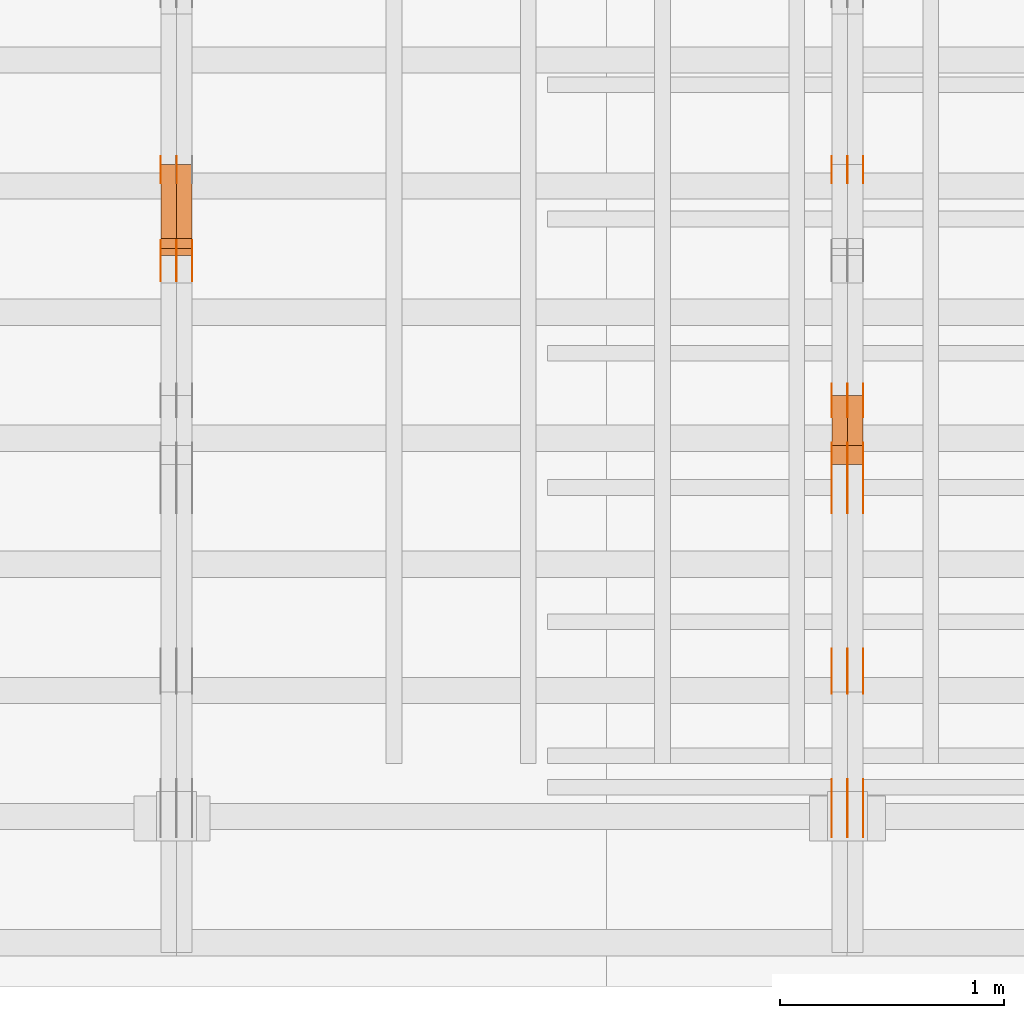
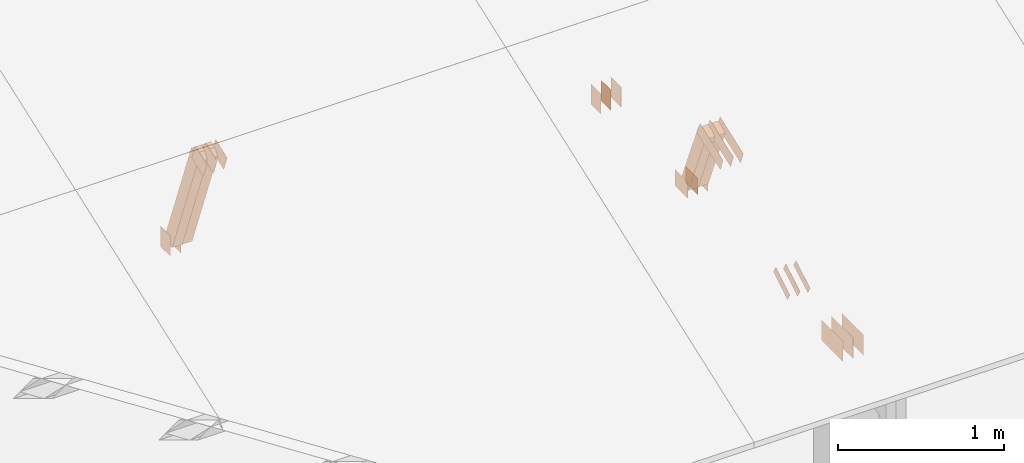
# One storey, part 141 of 189: 30 proxies.
"""IFC2X3 building model written with IfcOpenShell, lengths in millimetres."""

from ifc_helpers import new_model, entity, si_unit, converted_unit, derived_unit, direction, frame, frame_2d, origin, origin_2d_with_axis, place, context, subcontext, project, spatial, polyline, rectangle, outline, extrude, source, transform, mapped, material, type_object, type_shapes, element, save


model = new_model("IFC2X3")

# Units and contexts
model_context = context("Model", 3, precision=0.01, world=origin(), true_north=direction((6.12303176911189e-17, 1.0)))
body_context = subcontext(model_context, "Body", "Model", "MODEL_VIEW")
ifc_project = project(units=[si_unit("LENGTHUNIT", "METRE", prefix="MILLI"), si_unit("AREAUNIT", "SQUARE_METRE"), si_unit("VOLUMEUNIT", "CUBIC_METRE"), converted_unit("PLANEANGLEUNIT", "DEGREE", entity("IfcRatioMeasure", 0.0174532925199433), si_unit("PLANEANGLEUNIT", "RADIAN"), dimensions=[0, 0, 0, 0, 0, 0, 0]), si_unit("MASSUNIT", "GRAM", prefix="KILO"), derived_unit("MASSDENSITYUNIT", [(si_unit("MASSUNIT", "GRAM", prefix="KILO"), 1), (si_unit("LENGTHUNIT", "METRE"), -3)]), si_unit("TIMEUNIT", "SECOND"), si_unit("FREQUENCYUNIT", "HERTZ"), si_unit("THERMODYNAMICTEMPERATUREUNIT", "DEGREE_CELSIUS"), derived_unit("THERMALTRANSMITTANCEUNIT", [(si_unit("MASSUNIT", "GRAM", prefix="KILO"), 1), (si_unit("THERMODYNAMICTEMPERATUREUNIT", "KELVIN"), -1), (si_unit("TIMEUNIT", "SECOND"), -3)]), derived_unit("VOLUMETRICFLOWRATEUNIT", [(si_unit("LENGTHUNIT", "METRE"), 3), (si_unit("TIMEUNIT", "SECOND"), -1)]), si_unit("ELECTRICCURRENTUNIT", "AMPERE"), si_unit("ELECTRICVOLTAGEUNIT", "VOLT"), si_unit("POWERUNIT", "WATT"), si_unit("FORCEUNIT", "NEWTON"), si_unit("ILLUMINANCEUNIT", "LUX"), si_unit("LUMINOUSFLUXUNIT", "LUMEN"), si_unit("LUMINOUSINTENSITYUNIT", "CANDELA"), derived_unit("USERDEFINED", [(si_unit("MASSUNIT", "GRAM", prefix="KILO"), -1), (si_unit("LENGTHUNIT", "METRE"), -2), (si_unit("TIMEUNIT", "SECOND"), 3), (si_unit("LUMINOUSFLUXUNIT", "LUMEN"), 1)]), derived_unit("LINEARVELOCITYUNIT", [(si_unit("LENGTHUNIT", "METRE"), 1), (si_unit("TIMEUNIT", "SECOND"), -1)]), si_unit("PRESSUREUNIT", "PASCAL"), derived_unit("USERDEFINED", [(si_unit("LENGTHUNIT", "METRE"), -2), (si_unit("MASSUNIT", "GRAM", prefix="KILO"), 1), (si_unit("TIMEUNIT", "SECOND"), -2)])], contexts=[model_context])

# Site, building, storey
site_placement = place(None, origin())
site = spatial("IfcSite", under=ifc_project, at=site_placement, CompositionType="ELEMENT")
building_placement = place(site_placement, origin())
building = spatial("IfcBuilding", under=site, at=building_placement, CompositionType="ELEMENT")
storey_placement = place(building_placement, origin())
storey = spatial("IfcBuildingStorey", under=building, at=storey_placement, Name="Default", CompositionType="ELEMENT", Elevation=0.0)

# Proxies
ifc_material_1 = material(Name="IfcSurfaceStyle #247220")
building_element_proxy_type_1 = type_object("IfcBuildingElementProxyType", PredefinedType="NOTDEFINED", material=ifc_material_1)
shared_shape_1 = source(origin(), body_context, "Body", "SweptSolid", [
    extrude(rectangle(XDim=150.0, YDim=120.0, at=frame_2d((1.4210854715202e-14, -7.105427357601e-15), x_axis=(1.0, 0.0))), frame((75.0, 60.0004961323721, 0.0), z_axis=(0.0, 0.0, 1.0), x_axis=(-1.0, 0.0, 0.0)), (0.0, 0.0, 1.0), 1.3),
])
type_shapes(building_element_proxy_type_1, [shared_shape_1])
proxy_1_placement = place(building_placement, frame((45301.3, 2940.99169136763, 170.0), z_axis=(-1.0, 0.0, 0.0), x_axis=(0.0, 0.0, 1.0)))
element("IfcBuildingElementProxy", 1, at=proxy_1_placement, inside=storey, type_object=building_element_proxy_type_1, material=ifc_material_1, context=body_context, shape_type="MappedRepresentation", body=[
    mapped(shared_shape_1, transform((0.0, 0.0, 0.0), scale=1.0)),
])
ifc_material_2 = material(Name="IfcSurfaceStyle #247163")
building_element_proxy_type_2 = type_object("IfcBuildingElementProxyType", PredefinedType="NOTDEFINED", material=ifc_material_2)
shared_shape_2 = source(origin(), body_context, "Body", "SweptSolid", [
    extrude(rectangle(XDim=150.0, YDim=120.0, at=frame_2d((1.4210854715202e-14, -7.105427357601e-15), x_axis=(1.0, 0.0))), frame((75.0, 60.0004961323721, 0.0), z_axis=(0.0, 0.0, 1.0), x_axis=(-1.0, 0.0, 0.0)), (0.0, 0.0, 1.0), 1.29999999999999),
])
type_shapes(building_element_proxy_type_2, [shared_shape_2])
proxy_2_placement = place(building_placement, frame((45230.0, 2940.99169136763, 170.0), z_axis=(-1.0, 0.0, 0.0), x_axis=(0.0, 0.0, 1.0)))
element("IfcBuildingElementProxy", 2, at=proxy_2_placement, inside=storey, type_object=building_element_proxy_type_2, material=ifc_material_2, context=body_context, shape_type="MappedRepresentation", body=[
    mapped(shared_shape_2, transform((0.0, 0.0, 0.0), scale=1.0)),
])
ifc_material_3 = material(Name="IfcSurfaceStyle #247106")
building_element_proxy_type_3 = type_object("IfcBuildingElementProxyType", PredefinedType="NOTDEFINED", material=ifc_material_3)
shared_shape_3 = source(origin(), body_context, "Body", "SweptSolid", [
    extrude(rectangle(XDim=150.0, YDim=120.0, at=frame_2d((1.4210854715202e-14, -7.105427357601e-15), x_axis=(1.0, 0.0))), frame((75.0, 60.0004961323721, 0.0), z_axis=(0.0, 0.0, 1.0), x_axis=(-1.0, 0.0, 0.0)), (0.0, 0.0, 1.0), 1.29999999999999),
])
type_shapes(building_element_proxy_type_3, [shared_shape_3])
proxy_3_placement = place(building_placement, frame((45231.3, 2940.99169136763, 170.0), z_axis=(-1.0, 0.0, 0.0), x_axis=(0.0, 0.0, 1.0)))
element("IfcBuildingElementProxy", 3, at=proxy_3_placement, inside=storey, type_object=building_element_proxy_type_3, material=ifc_material_3, context=body_context, shape_type="MappedRepresentation", body=[
    mapped(shared_shape_3, transform((0.0, 0.0, 0.0), scale=1.0)),
])
ifc_material_4 = material(Name="IfcSurfaceStyle #247049")
building_element_proxy_type_4 = type_object("IfcBuildingElementProxyType", PredefinedType="NOTDEFINED", material=ifc_material_4)
shared_shape_4 = source(origin(), body_context, "Body", "SweptSolid", [
    extrude(rectangle(XDim=150.0, YDim=120.0, at=frame_2d((1.4210854715202e-14, -7.105427357601e-15), x_axis=(1.0, 0.0))), frame((75.0, 60.0004961323721, 0.0), z_axis=(0.0, 0.0, 1.0), x_axis=(-1.0, 0.0, 0.0)), (0.0, 0.0, 1.0), 1.29999999999999),
])
type_shapes(building_element_proxy_type_4, [shared_shape_4])
proxy_4_placement = place(building_placement, frame((45160.0, 2940.99169136763, 170.0), z_axis=(-1.0, 0.0, 0.0), x_axis=(0.0, 0.0, 1.0)))
element("IfcBuildingElementProxy", 4, at=proxy_4_placement, inside=storey, type_object=building_element_proxy_type_4, material=ifc_material_4, context=body_context, shape_type="MappedRepresentation", body=[
    mapped(shared_shape_4, transform((0.0, 0.0, 0.0), scale=1.0)),
])
ifc_material_5 = material(Name="IfcSurfaceStyle #246308")
building_element_proxy_type_5 = type_object("IfcBuildingElementProxyType", PredefinedType="NOTDEFINED", material=ifc_material_5)
shared_shape_5 = source(origin(), body_context, "Body", "SweptSolid", [
    extrude(rectangle(XDim=150.0, YDim=120.0, at=origin_2d_with_axis()), frame((75.0004757715869, 60.0, 0.0), z_axis=(0.0, 0.0, 1.0), x_axis=(-1.0, 0.0, 0.0)), (0.0, 0.0, 1.0), 1.3),
])
type_shapes(building_element_proxy_type_5, [shared_shape_5])
proxy_5_placement = place(building_placement, frame((45301.3, 1892.68702422841, 305.0), z_axis=(-1.0, 0.0, 0.0), x_axis=(0.0, 1.0, 0.0)))
element("IfcBuildingElementProxy", 5, at=proxy_5_placement, inside=storey, type_object=building_element_proxy_type_5, material=ifc_material_5, context=body_context, shape_type="MappedRepresentation", body=[
    mapped(shared_shape_5, transform((0.0, 0.0, 0.0), scale=1.0)),
])
ifc_material_6 = material(Name="IfcSurfaceStyle #246251")
building_element_proxy_type_6 = type_object("IfcBuildingElementProxyType", PredefinedType="NOTDEFINED", material=ifc_material_6)
shared_shape_6 = source(origin(), body_context, "Body", "SweptSolid", [
    extrude(rectangle(XDim=150.0, YDim=120.0, at=origin_2d_with_axis()), frame((75.0004757715869, 60.0, 0.0), z_axis=(0.0, 0.0, 1.0), x_axis=(-1.0, 0.0, 0.0)), (0.0, 0.0, 1.0), 1.29999999999999),
])
type_shapes(building_element_proxy_type_6, [shared_shape_6])
proxy_6_placement = place(building_placement, frame((45230.0, 1892.68702422841, 305.0), z_axis=(-1.0, 0.0, 0.0), x_axis=(0.0, 1.0, 0.0)))
element("IfcBuildingElementProxy", 6, at=proxy_6_placement, inside=storey, type_object=building_element_proxy_type_6, material=ifc_material_6, context=body_context, shape_type="MappedRepresentation", body=[
    mapped(shared_shape_6, transform((0.0, 0.0, 0.0), scale=1.0)),
])
ifc_material_7 = material(Name="IfcSurfaceStyle #246194")
building_element_proxy_type_7 = type_object("IfcBuildingElementProxyType", PredefinedType="NOTDEFINED", material=ifc_material_7)
shared_shape_7 = source(origin(), body_context, "Body", "SweptSolid", [
    extrude(rectangle(XDim=150.0, YDim=120.0, at=origin_2d_with_axis()), frame((75.0004757715869, 60.0, 0.0), z_axis=(0.0, 0.0, 1.0), x_axis=(-1.0, 0.0, 0.0)), (0.0, 0.0, 1.0), 1.29999999999999),
])
type_shapes(building_element_proxy_type_7, [shared_shape_7])
proxy_7_placement = place(building_placement, frame((45231.3, 1892.68702422841, 305.0), z_axis=(-1.0, 0.0, 0.0), x_axis=(0.0, 1.0, 0.0)))
element("IfcBuildingElementProxy", 7, at=proxy_7_placement, inside=storey, type_object=building_element_proxy_type_7, material=ifc_material_7, context=body_context, shape_type="MappedRepresentation", body=[
    mapped(shared_shape_7, transform((0.0, 0.0, 0.0), scale=1.0)),
])
ifc_material_8 = material(Name="IfcSurfaceStyle #246137")
building_element_proxy_type_8 = type_object("IfcBuildingElementProxyType", PredefinedType="NOTDEFINED", material=ifc_material_8)
shared_shape_8 = source(origin(), body_context, "Body", "SweptSolid", [
    extrude(rectangle(XDim=150.0, YDim=120.0, at=origin_2d_with_axis()), frame((75.0004757715869, 60.0, 0.0), z_axis=(0.0, 0.0, 1.0), x_axis=(-1.0, 0.0, 0.0)), (0.0, 0.0, 1.0), 1.29999999999999),
])
type_shapes(building_element_proxy_type_8, [shared_shape_8])
proxy_8_placement = place(building_placement, frame((45160.0, 1892.68702422841, 305.0), z_axis=(-1.0, 0.0, 0.0), x_axis=(0.0, 1.0, 0.0)))
element("IfcBuildingElementProxy", 8, at=proxy_8_placement, inside=storey, type_object=building_element_proxy_type_8, material=ifc_material_8, context=body_context, shape_type="MappedRepresentation", body=[
    mapped(shared_shape_8, transform((0.0, 0.0, 0.0), scale=1.0)),
])
ifc_material_9 = material(Name="IfcSurfaceStyle #246080")
building_element_proxy_type_9 = type_object("IfcBuildingElementProxyType", PredefinedType="NOTDEFINED", material=ifc_material_9)
shared_shape_9 = source(origin(), body_context, "Body", "SweptSolid", [
    extrude(outline(polyline([(-150.000217420008, -47.9999344162752), (150.000165800718, -47.9999344162752), (150.000227857633, 47.9999344162752), (-150.000176238343, 47.9999344162752), (-150.000217420008, -47.9999344162752)])), frame((150.000227857633, 48.0000430742566, 0.0), z_axis=(0.0, 0.0, 1.0), x_axis=(-1.0, 0.0, 0.0)), (0.0, 0.0, 1.0), 1.29999999999999),
])
type_shapes(building_element_proxy_type_9, [shared_shape_9])
proxy_9_placement = place(building_placement, frame((45301.3, 1464.46484375, 723.378723144533), z_axis=(-1.0, 0.0, 0.0), x_axis=(0.0, 0.939692620785908, 0.342020143325669)))
element("IfcBuildingElementProxy", 9, at=proxy_9_placement, inside=storey, type_object=building_element_proxy_type_9, material=ifc_material_9, context=body_context, shape_type="MappedRepresentation", body=[
    mapped(shared_shape_9, transform((0.0, 0.0, 0.0), scale=1.0)),
])
ifc_material_10 = material(Name="IfcSurfaceStyle #246023")
building_element_proxy_type_10 = type_object("IfcBuildingElementProxyType", PredefinedType="NOTDEFINED", material=ifc_material_10)
shared_shape_10 = source(origin(), body_context, "Body", "SweptSolid", [
    extrude(outline(polyline([(-150.000217420008, -47.9999344162752), (150.000165800718, -47.9999344162752), (150.000227857633, 47.9999344162752), (-150.000176238343, 47.9999344162752), (-150.000217420008, -47.9999344162752)])), frame((150.000227857633, 48.0000430742566, 0.0), z_axis=(0.0, 0.0, 1.0), x_axis=(-1.0, 0.0, 0.0)), (0.0, 0.0, 1.0), 1.29999999999998),
])
type_shapes(building_element_proxy_type_10, [shared_shape_10])
proxy_10_placement = place(building_placement, frame((45230.0, 1464.46484375, 723.378723144533), z_axis=(-1.0, 0.0, 0.0), x_axis=(0.0, 0.939692620785908, 0.342020143325669)))
element("IfcBuildingElementProxy", 10, at=proxy_10_placement, inside=storey, type_object=building_element_proxy_type_10, material=ifc_material_10, context=body_context, shape_type="MappedRepresentation", body=[
    mapped(shared_shape_10, transform((0.0, 0.0, 0.0), scale=1.0)),
])
ifc_material_11 = material(Name="IfcSurfaceStyle #245966")
building_element_proxy_type_11 = type_object("IfcBuildingElementProxyType", PredefinedType="NOTDEFINED", material=ifc_material_11)
shared_shape_11 = source(origin(), body_context, "Body", "SweptSolid", [
    extrude(outline(polyline([(-150.000217420008, -47.9999344162752), (150.000165800718, -47.9999344162752), (150.000227857633, 47.9999344162752), (-150.000176238343, 47.9999344162752), (-150.000217420008, -47.9999344162752)])), frame((150.000227857633, 48.0000430742566, 0.0), z_axis=(0.0, 0.0, 1.0), x_axis=(-1.0, 0.0, 0.0)), (0.0, 0.0, 1.0), 1.29999999999998),
])
type_shapes(building_element_proxy_type_11, [shared_shape_11])
proxy_11_placement = place(building_placement, frame((45231.3, 1464.46484375, 723.378723144533), z_axis=(-1.0, 0.0, 0.0), x_axis=(0.0, 0.939692620785908, 0.342020143325669)))
element("IfcBuildingElementProxy", 11, at=proxy_11_placement, inside=storey, type_object=building_element_proxy_type_11, material=ifc_material_11, context=body_context, shape_type="MappedRepresentation", body=[
    mapped(shared_shape_11, transform((0.0, 0.0, 0.0), scale=1.0)),
])
ifc_material_12 = material(Name="IfcSurfaceStyle #245909")
building_element_proxy_type_12 = type_object("IfcBuildingElementProxyType", PredefinedType="NOTDEFINED", material=ifc_material_12)
shared_shape_12 = source(origin(), body_context, "Body", "SweptSolid", [
    extrude(outline(polyline([(-150.000217420008, -47.9999344162752), (150.000165800718, -47.9999344162752), (150.000227857633, 47.9999344162752), (-150.000176238343, 47.9999344162752), (-150.000217420008, -47.9999344162752)])), frame((150.000227857633, 48.0000430742566, 0.0), z_axis=(0.0, 0.0, 1.0), x_axis=(-1.0, 0.0, 0.0)), (0.0, 0.0, 1.0), 1.29999999999998),
])
type_shapes(building_element_proxy_type_12, [shared_shape_12])
proxy_12_placement = place(building_placement, frame((45160.0, 1464.46484375, 723.378723144533), z_axis=(-1.0, 0.0, 0.0), x_axis=(0.0, 0.939692620785908, 0.342020143325669)))
element("IfcBuildingElementProxy", 12, at=proxy_12_placement, inside=storey, type_object=building_element_proxy_type_12, material=ifc_material_12, context=body_context, shape_type="MappedRepresentation", body=[
    mapped(shared_shape_12, transform((0.0, 0.0, 0.0), scale=1.0)),
])
ifc_material_13 = material(Name="IfcSurfaceStyle #245396")
building_element_proxy_type_13 = type_object("IfcBuildingElementProxyType", PredefinedType="NOTDEFINED", material=ifc_material_13)
shared_shape_13 = source(origin(), body_context, "Body", "SweptSolid", [
    extrude(outline(polyline([(-100.000388510424, -29.9995882393532), (100.000691805256, -29.9995882393532), (100.000392424258, 29.9995882393532), (-100.00069571909, 29.9995882393532), (-100.000388510424, -29.9995882393532)])), frame((100.000691805256, 30.0002299338894, 0.0), z_axis=(0.0, 0.0, 1.0), x_axis=(-1.0, 0.0, 0.0)), (0.0, 0.0, 1.0), 1.3),
])
type_shapes(building_element_proxy_type_13, [shared_shape_13])
proxy_13_placement = place(building_placement, frame((45301.3, 656.945055513712, 219.45219322107), z_axis=(-1.0, 0.0, 0.0), x_axis=(0.0, 0.858392121304013, 0.51299411895576)))
element("IfcBuildingElementProxy", 13, at=proxy_13_placement, inside=storey, type_object=building_element_proxy_type_13, material=ifc_material_13, context=body_context, shape_type="MappedRepresentation", body=[
    mapped(shared_shape_13, transform((0.0, 0.0, 0.0), scale=1.0)),
])
ifc_material_14 = material(Name="IfcSurfaceStyle #245339")
building_element_proxy_type_14 = type_object("IfcBuildingElementProxyType", PredefinedType="NOTDEFINED", material=ifc_material_14)
shared_shape_14 = source(origin(), body_context, "Body", "SweptSolid", [
    extrude(outline(polyline([(-100.000388510424, -29.9995882393532), (100.000691805256, -29.9995882393532), (100.000392424258, 29.9995882393532), (-100.00069571909, 29.9995882393532), (-100.000388510424, -29.9995882393532)])), frame((100.000691805256, 30.0002299338894, 0.0), z_axis=(0.0, 0.0, 1.0), x_axis=(-1.0, 0.0, 0.0)), (0.0, 0.0, 1.0), 1.29999999999998),
])
type_shapes(building_element_proxy_type_14, [shared_shape_14])
proxy_14_placement = place(building_placement, frame((45230.0, 656.945055513712, 219.45219322107), z_axis=(-1.0, 0.0, 0.0), x_axis=(0.0, 0.858392121304013, 0.51299411895576)))
element("IfcBuildingElementProxy", 14, at=proxy_14_placement, inside=storey, type_object=building_element_proxy_type_14, material=ifc_material_14, context=body_context, shape_type="MappedRepresentation", body=[
    mapped(shared_shape_14, transform((0.0, 0.0, 0.0), scale=1.0)),
])
ifc_material_15 = material(Name="IfcSurfaceStyle #245282")
building_element_proxy_type_15 = type_object("IfcBuildingElementProxyType", PredefinedType="NOTDEFINED", material=ifc_material_15)
shared_shape_15 = source(origin(), body_context, "Body", "SweptSolid", [
    extrude(outline(polyline([(-100.000388510424, -29.9995882393532), (100.000691805256, -29.9995882393532), (100.000392424258, 29.9995882393532), (-100.00069571909, 29.9995882393532), (-100.000388510424, -29.9995882393532)])), frame((100.000691805256, 30.0002299338894, 0.0), z_axis=(0.0, 0.0, 1.0), x_axis=(-1.0, 0.0, 0.0)), (0.0, 0.0, 1.0), 1.29999999999998),
])
type_shapes(building_element_proxy_type_15, [shared_shape_15])
proxy_15_placement = place(building_placement, frame((45231.3, 656.945055513712, 219.45219322107), z_axis=(-1.0, 0.0, 0.0), x_axis=(0.0, 0.858392121304013, 0.51299411895576)))
element("IfcBuildingElementProxy", 15, at=proxy_15_placement, inside=storey, type_object=building_element_proxy_type_15, material=ifc_material_15, context=body_context, shape_type="MappedRepresentation", body=[
    mapped(shared_shape_15, transform((0.0, 0.0, 0.0), scale=1.0)),
])
ifc_material_16 = material(Name="IfcSurfaceStyle #245225")
building_element_proxy_type_16 = type_object("IfcBuildingElementProxyType", PredefinedType="NOTDEFINED", material=ifc_material_16)
shared_shape_16 = source(origin(), body_context, "Body", "SweptSolid", [
    extrude(outline(polyline([(-100.000388510424, -29.9995882393532), (100.000691805256, -29.9995882393532), (100.000392424258, 29.9995882393532), (-100.00069571909, 29.9995882393532), (-100.000388510424, -29.9995882393532)])), frame((100.000691805256, 30.0002299338894, 0.0), z_axis=(0.0, 0.0, 1.0), x_axis=(-1.0, 0.0, 0.0)), (0.0, 0.0, 1.0), 1.29999999999999),
])
type_shapes(building_element_proxy_type_16, [shared_shape_16])
proxy_16_placement = place(building_placement, frame((45160.0, 656.945055513712, 219.45219322107), z_axis=(-1.0, 0.0, 0.0), x_axis=(0.0, 0.858392121304013, 0.51299411895576)))
element("IfcBuildingElementProxy", 16, at=proxy_16_placement, inside=storey, type_object=building_element_proxy_type_16, material=ifc_material_16, context=body_context, shape_type="MappedRepresentation", body=[
    mapped(shared_shape_16, transform((0.0, 0.0, 0.0), scale=1.0)),
])
ifc_material_17 = material(Name="IfcSurfaceStyle #243860")
building_element_proxy_type_17 = type_object("IfcBuildingElementProxyType", PredefinedType="NOTDEFINED", material=ifc_material_17)
shared_shape_17 = source(origin(), body_context, "Body", "SweptSolid", [
    extrude(rectangle(XDim=258.0, YDim=151.999992370605, at=origin_2d_with_axis()), frame((129.0, 76.0000049445079, 0.0), z_axis=(0.0, 0.0, 1.0), x_axis=(-1.0, 0.0, 0.0)), (0.0, 0.0, 1.0), 0.999999999999984),
])
type_shapes(building_element_proxy_type_17, [shared_shape_17])
proxy_17_placement = place(building_placement, frame((45301.0, 16.236328125, 268.138222870533), z_axis=(-1.0, 0.0, 0.0), x_axis=(0.0, 1.0, 0.0)))
element("IfcBuildingElementProxy", 17, at=proxy_17_placement, inside=storey, type_object=building_element_proxy_type_17, material=ifc_material_17, Name="GNT100S 152x258", context=body_context, shape_type="MappedRepresentation", body=[
    mapped(shared_shape_17, transform((0.0, 0.0, 0.0), scale=1.0)),
])
ifc_material_18 = material(Name="IfcSurfaceStyle #243803")
building_element_proxy_type_18 = type_object("IfcBuildingElementProxyType", PredefinedType="NOTDEFINED", material=ifc_material_18)
shared_shape_18 = source(origin(), body_context, "Body", "SweptSolid", [
    extrude(rectangle(XDim=258.0, YDim=151.999992370605, at=origin_2d_with_axis()), frame((129.0, 76.0000049445079, 0.0), z_axis=(0.0, 0.0, 1.0), x_axis=(-1.0, 0.0, 0.0)), (0.0, 0.0, 1.0), 0.999999999999984),
])
type_shapes(building_element_proxy_type_18, [shared_shape_18])
proxy_18_placement = place(building_placement, frame((45230.0, 16.236328125, 268.138222870533), z_axis=(-1.0, 0.0, 0.0), x_axis=(0.0, 1.0, 0.0)))
element("IfcBuildingElementProxy", 18, at=proxy_18_placement, inside=storey, type_object=building_element_proxy_type_18, material=ifc_material_18, Name="GNT100S 152x258", context=body_context, shape_type="MappedRepresentation", body=[
    mapped(shared_shape_18, transform((0.0, 0.0, 0.0), scale=1.0)),
])
ifc_material_19 = material(Name="IfcSurfaceStyle #243746")
building_element_proxy_type_19 = type_object("IfcBuildingElementProxyType", PredefinedType="NOTDEFINED", material=ifc_material_19)
shared_shape_19 = source(origin(), body_context, "Body", "SweptSolid", [
    extrude(rectangle(XDim=258.0, YDim=151.999992370605, at=origin_2d_with_axis()), frame((129.0, 76.0000049445079, 0.0), z_axis=(0.0, 0.0, 1.0), x_axis=(-1.0, 0.0, 0.0)), (0.0, 0.0, 1.0), 0.999999999999984),
])
type_shapes(building_element_proxy_type_19, [shared_shape_19])
proxy_19_placement = place(building_placement, frame((45231.0, 16.236328125, 268.138222870533), z_axis=(-1.0, 0.0, 0.0), x_axis=(0.0, 1.0, 0.0)))
element("IfcBuildingElementProxy", 19, at=proxy_19_placement, inside=storey, type_object=building_element_proxy_type_19, material=ifc_material_19, Name="GNT100S 152x258", context=body_context, shape_type="MappedRepresentation", body=[
    mapped(shared_shape_19, transform((0.0, 0.0, 0.0), scale=1.0)),
])
ifc_material_20 = material(Name="IfcSurfaceStyle #243689")
building_element_proxy_type_20 = type_object("IfcBuildingElementProxyType", PredefinedType="NOTDEFINED", material=ifc_material_20)
shared_shape_20 = source(origin(), body_context, "Body", "SweptSolid", [
    extrude(rectangle(XDim=258.0, YDim=151.999992370605, at=origin_2d_with_axis()), frame((129.0, 76.0000049445079, 0.0), z_axis=(0.0, 0.0, 1.0), x_axis=(-1.0, 0.0, 0.0)), (0.0, 0.0, 1.0), 0.999999999999984),
])
type_shapes(building_element_proxy_type_20, [shared_shape_20])
proxy_20_placement = place(building_placement, frame((45160.0, 16.236328125, 268.138222870533), z_axis=(-1.0, 0.0, 0.0), x_axis=(0.0, 1.0, 0.0)))
element("IfcBuildingElementProxy", 20, at=proxy_20_placement, inside=storey, type_object=building_element_proxy_type_20, material=ifc_material_20, Name="GNT100S 152x258", context=body_context, shape_type="MappedRepresentation", body=[
    mapped(shared_shape_20, transform((0.0, 0.0, 0.0), scale=1.0)),
])
ifc_material_21 = material(Name="IfcSurfaceStyle #238892")
building_element_proxy_type_21 = type_object("IfcBuildingElementProxyType", Name="T1-W15 238890", PredefinedType="NOTDEFINED", material=ifc_material_21)
shared_shape_21 = source(origin(), body_context, "Body", "SweptSolid", [
    extrude(outline(polyline([(-317.132720418368, -47.5005147440206), (220.445242566881, -47.5005147440206), (227.5021778825, -0.000126286009697951), (225.500088907744, 47.5005778870255), (-356.314788938758, 47.5005778870255), (-317.132720418368, -47.5005147440206)])), frame((227.5021778825, 47.5005778870255, 0.0), z_axis=(0.0, 0.0, 1.0), x_axis=(-1.0, 0.0, 0.0)), (0.0, 0.0, 1.0), 70.0),
])
type_shapes(building_element_proxy_type_21, [shared_shape_21])
proxy_21_placement = place(building_placement, frame((45300.0, 1767.47882447529, 784.714556181707), z_axis=(-1.0, 0.0, 0.0), x_axis=(0.0, 0.381283266795389, -0.924458257825542)))
element("IfcBuildingElementProxy", 21, at=proxy_21_placement, inside=storey, type_object=building_element_proxy_type_21, material=ifc_material_21, Name="T1-W15", context=body_context, shape_type="MappedRepresentation", body=[
    mapped(shared_shape_21, transform((0.0, 0.0, 0.0), scale=1.0)),
])
ifc_material_22 = material(Name="IfcSurfaceStyle #238826")
building_element_proxy_type_22 = type_object("IfcBuildingElementProxyType", Name="T1-W15 238824", PredefinedType="NOTDEFINED", material=ifc_material_22)
shared_shape_22 = source(origin(), body_context, "Body", "SweptSolid", [
    extrude(outline(polyline([(-317.132720418368, -47.5005147440206), (220.445242566881, -47.5005147440206), (227.5021778825, -0.000126286009697951), (225.500088907744, 47.5005778870255), (-356.314788938758, 47.5005778870255), (-317.132720418368, -47.5005147440206)])), frame((227.5021778825, 47.5005778870255, 0.0), z_axis=(0.0, 0.0, 1.0), x_axis=(-1.0, 0.0, 0.0)), (0.0, 0.0, 1.0), 70.0),
])
type_shapes(building_element_proxy_type_22, [shared_shape_22])
proxy_22_placement = place(building_placement, frame((45230.0, 1767.47882447529, 784.714556181707), z_axis=(-1.0, 0.0, 0.0), x_axis=(0.0, 0.381283266795389, -0.924458257825542)))
element("IfcBuildingElementProxy", 22, at=proxy_22_placement, inside=storey, type_object=building_element_proxy_type_22, material=ifc_material_22, Name="T1-W15", context=body_context, shape_type="MappedRepresentation", body=[
    mapped(shared_shape_22, transform((0.0, 0.0, 0.0), scale=1.0)),
])
ifc_material_23 = material(Name="IfcSurfaceStyle #231316")
building_element_proxy_type_23 = type_object("IfcBuildingElementProxyType", PredefinedType="NOTDEFINED", material=ifc_material_23)
shared_shape_23 = source(origin(), body_context, "Body", "SweptSolid", [
    extrude(rectangle(XDim=150.0, YDim=120.0, at=frame_2d((1.4210854715202e-14, -7.105427357601e-15), x_axis=(1.0, 0.0))), frame((75.0, 60.0004961323721, 0.0), z_axis=(0.0, 0.0, 1.0), x_axis=(-1.0, 0.0, 0.0)), (0.0, 0.0, 1.0), 1.29999999999999),
])
type_shapes(building_element_proxy_type_23, [shared_shape_23])
proxy_23_placement = place(building_placement, frame((42231.3, 2940.99169136763, 170.0), z_axis=(-1.0, 0.0, 0.0), x_axis=(0.0, 0.0, 1.0)))
element("IfcBuildingElementProxy", 23, at=proxy_23_placement, inside=storey, type_object=building_element_proxy_type_23, material=ifc_material_23, context=body_context, shape_type="MappedRepresentation", body=[
    mapped(shared_shape_23, transform((0.0, 0.0, 0.0), scale=1.0)),
])
ifc_material_24 = material(Name="IfcSurfaceStyle #231259")
building_element_proxy_type_24 = type_object("IfcBuildingElementProxyType", PredefinedType="NOTDEFINED", material=ifc_material_24)
shared_shape_24 = source(origin(), body_context, "Body", "SweptSolid", [
    extrude(rectangle(XDim=150.0, YDim=120.0, at=frame_2d((1.4210854715202e-14, -7.105427357601e-15), x_axis=(1.0, 0.0))), frame((75.0, 60.0004961323721, 0.0), z_axis=(0.0, 0.0, 1.0), x_axis=(-1.0, 0.0, 0.0)), (0.0, 0.0, 1.0), 1.29999999999999),
])
type_shapes(building_element_proxy_type_24, [shared_shape_24])
proxy_24_placement = place(building_placement, frame((42160.0, 2940.99169136763, 170.0), z_axis=(-1.0, 0.0, 0.0), x_axis=(0.0, 0.0, 1.0)))
element("IfcBuildingElementProxy", 24, at=proxy_24_placement, inside=storey, type_object=building_element_proxy_type_24, material=ifc_material_24, context=body_context, shape_type="MappedRepresentation", body=[
    mapped(shared_shape_24, transform((0.0, 0.0, 0.0), scale=1.0)),
])
ifc_material_25 = material(Name="IfcSurfaceStyle #231202")
building_element_proxy_type_25 = type_object("IfcBuildingElementProxyType", PredefinedType="NOTDEFINED", material=ifc_material_25)
shared_shape_25 = source(origin(), body_context, "Body", "SweptSolid", [
    extrude(outline(polyline([(-75.0008071857483, -59.9999039432187), (75.0002916555677, -59.9999039432187), (75.0008280609982, 59.9999039432187), (-75.0003125308176, 59.9999039432187), (-75.0008071857483, -59.9999039432187)])), frame((75.0008280609982, 60.0002349219685, 0.0), z_axis=(0.0, 0.0, 1.0), x_axis=(-1.0, 0.0, 0.0)), (0.0, 0.0, 1.0), 1.3),
])
type_shapes(building_element_proxy_type_25, [shared_shape_25])
proxy_25_placement = place(building_placement, frame((42301.3, 2502.466796875, 1113.95080566406), z_axis=(-1.0, 0.0, 0.0), x_axis=(0.0, 0.939692620785908, 0.342020143325669)))
element("IfcBuildingElementProxy", 25, at=proxy_25_placement, inside=storey, type_object=building_element_proxy_type_25, material=ifc_material_25, context=body_context, shape_type="MappedRepresentation", body=[
    mapped(shared_shape_25, transform((0.0, 0.0, 0.0), scale=1.0)),
])
ifc_material_26 = material(Name="IfcSurfaceStyle #231145")
building_element_proxy_type_26 = type_object("IfcBuildingElementProxyType", PredefinedType="NOTDEFINED", material=ifc_material_26)
shared_shape_26 = source(origin(), body_context, "Body", "SweptSolid", [
    extrude(outline(polyline([(-75.0008071857483, -59.9999039432187), (75.0002916555677, -59.9999039432187), (75.0008280609982, 59.9999039432187), (-75.0003125308176, 59.9999039432187), (-75.0008071857483, -59.9999039432187)])), frame((75.0008280609982, 60.0002349219685, 0.0), z_axis=(0.0, 0.0, 1.0), x_axis=(-1.0, 0.0, 0.0)), (0.0, 0.0, 1.0), 1.29999999999999),
])
type_shapes(building_element_proxy_type_26, [shared_shape_26])
proxy_26_placement = place(building_placement, frame((42230.0, 2502.466796875, 1113.95080566406), z_axis=(-1.0, 0.0, 0.0), x_axis=(0.0, 0.939692620785908, 0.342020143325669)))
element("IfcBuildingElementProxy", 26, at=proxy_26_placement, inside=storey, type_object=building_element_proxy_type_26, material=ifc_material_26, context=body_context, shape_type="MappedRepresentation", body=[
    mapped(shared_shape_26, transform((0.0, 0.0, 0.0), scale=1.0)),
])
ifc_material_27 = material(Name="IfcSurfaceStyle #231088")
building_element_proxy_type_27 = type_object("IfcBuildingElementProxyType", PredefinedType="NOTDEFINED", material=ifc_material_27)
shared_shape_27 = source(origin(), body_context, "Body", "SweptSolid", [
    extrude(outline(polyline([(-75.0008071857483, -59.9999039432187), (75.0002916555677, -59.9999039432187), (75.0008280609982, 59.9999039432187), (-75.0003125308176, 59.9999039432187), (-75.0008071857483, -59.9999039432187)])), frame((75.0008280609982, 60.0002349219685, 0.0), z_axis=(0.0, 0.0, 1.0), x_axis=(-1.0, 0.0, 0.0)), (0.0, 0.0, 1.0), 1.29999999999999),
])
type_shapes(building_element_proxy_type_27, [shared_shape_27])
proxy_27_placement = place(building_placement, frame((42231.3, 2502.466796875, 1113.95080566406), z_axis=(-1.0, 0.0, 0.0), x_axis=(0.0, 0.939692620785908, 0.342020143325669)))
element("IfcBuildingElementProxy", 27, at=proxy_27_placement, inside=storey, type_object=building_element_proxy_type_27, material=ifc_material_27, context=body_context, shape_type="MappedRepresentation", body=[
    mapped(shared_shape_27, transform((0.0, 0.0, 0.0), scale=1.0)),
])
ifc_material_28 = material(Name="IfcSurfaceStyle #231031")
building_element_proxy_type_28 = type_object("IfcBuildingElementProxyType", PredefinedType="NOTDEFINED", material=ifc_material_28)
shared_shape_28 = source(origin(), body_context, "Body", "SweptSolid", [
    extrude(outline(polyline([(-75.0008071857483, -59.9999039432187), (75.0002916555677, -59.9999039432187), (75.0008280609982, 59.9999039432187), (-75.0003125308176, 59.9999039432187), (-75.0008071857483, -59.9999039432187)])), frame((75.0008280609982, 60.0002349219685, 0.0), z_axis=(0.0, 0.0, 1.0), x_axis=(-1.0, 0.0, 0.0)), (0.0, 0.0, 1.0), 1.29999999999999),
])
type_shapes(building_element_proxy_type_28, [shared_shape_28])
proxy_28_placement = place(building_placement, frame((42160.0, 2502.466796875, 1113.95080566406), z_axis=(-1.0, 0.0, 0.0), x_axis=(0.0, 0.939692620785908, 0.342020143325669)))
element("IfcBuildingElementProxy", 28, at=proxy_28_placement, inside=storey, type_object=building_element_proxy_type_28, material=ifc_material_28, context=body_context, shape_type="MappedRepresentation", body=[
    mapped(shared_shape_28, transform((0.0, 0.0, 0.0), scale=1.0)),
])
ifc_material_29 = material(Name="IfcSurfaceStyle #223630")
building_element_proxy_type_29 = type_object("IfcBuildingElementProxyType", Name="T1-W14 223628", PredefinedType="NOTDEFINED", material=ifc_material_29)
shared_shape_29 = source(origin(), body_context, "Body", "SweptSolid", [
    extrude(outline(polyline([(-526.068269984593, -47.5004595774917), (341.27769108205, -47.5004595774917), (373.679499344758, 0.000392511719837607), (373.092506900368, 47.5002633216318), (-561.981427342584, 47.5002633216318), (-526.068269984593, -47.5004595774917)])), frame((373.67978783425, 47.5005221796964, 0.0), z_axis=(0.0, 0.0, 1.0), x_axis=(-1.0, 0.0, 0.0)), (0.0, 0.0, 1.0), 69.9999999999999),
])
type_shapes(building_element_proxy_type_29, [shared_shape_29])
proxy_29_placement = place(building_placement, frame((42300.0, 2693.38241954499, 1120.21215048788), z_axis=(-1.0, 0.0, 0.0), x_axis=(0.0, 0.353606472447916, -0.935394281916958)))
element("IfcBuildingElementProxy", 29, at=proxy_29_placement, inside=storey, type_object=building_element_proxy_type_29, material=ifc_material_29, Name="T1-W14", context=body_context, shape_type="MappedRepresentation", body=[
    mapped(shared_shape_29, transform((0.0, 0.0, 0.0), scale=1.0)),
])
ifc_material_30 = material(Name="IfcSurfaceStyle #223564")
building_element_proxy_type_30 = type_object("IfcBuildingElementProxyType", Name="T1-W14 223562", PredefinedType="NOTDEFINED", material=ifc_material_30)
shared_shape_30 = source(origin(), body_context, "Body", "SweptSolid", [
    extrude(outline(polyline([(-526.068269984593, -47.5004595774917), (341.27769108205, -47.5004595774917), (373.679499344758, 0.000392511719837607), (373.092506900368, 47.5002633216318), (-561.981427342584, 47.5002633216318), (-526.068269984593, -47.5004595774917)])), frame((373.67978783425, 47.5005221796964, 0.0), z_axis=(0.0, 0.0, 1.0), x_axis=(-1.0, 0.0, 0.0)), (0.0, 0.0, 1.0), 69.9999999999999),
])
type_shapes(building_element_proxy_type_30, [shared_shape_30])
proxy_30_placement = place(building_placement, frame((42230.0, 2693.38241954499, 1120.21215048788), z_axis=(-1.0, 0.0, 0.0), x_axis=(0.0, 0.353606472447916, -0.935394281916958)))
element("IfcBuildingElementProxy", 30, at=proxy_30_placement, inside=storey, type_object=building_element_proxy_type_30, material=ifc_material_30, Name="T1-W14", context=body_context, shape_type="MappedRepresentation", body=[
    mapped(shared_shape_30, transform((0.0, 0.0, 0.0), scale=1.0)),
])

save(model, "model.ifc")
